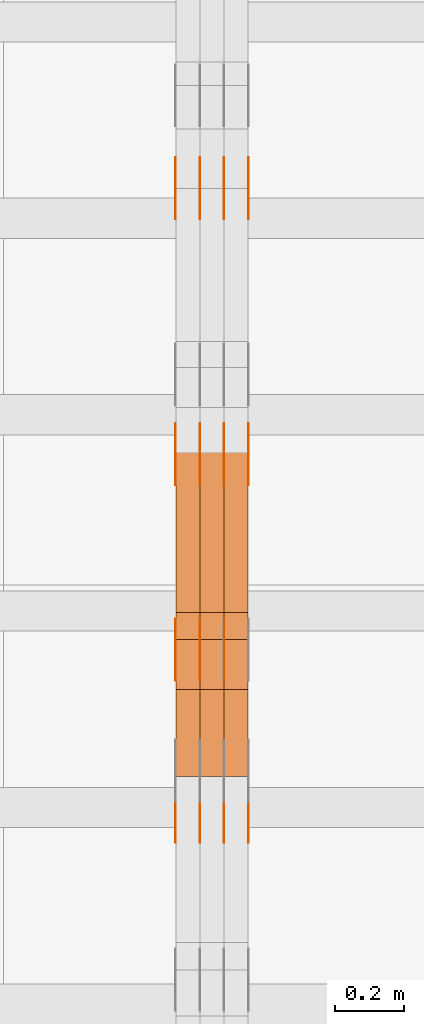
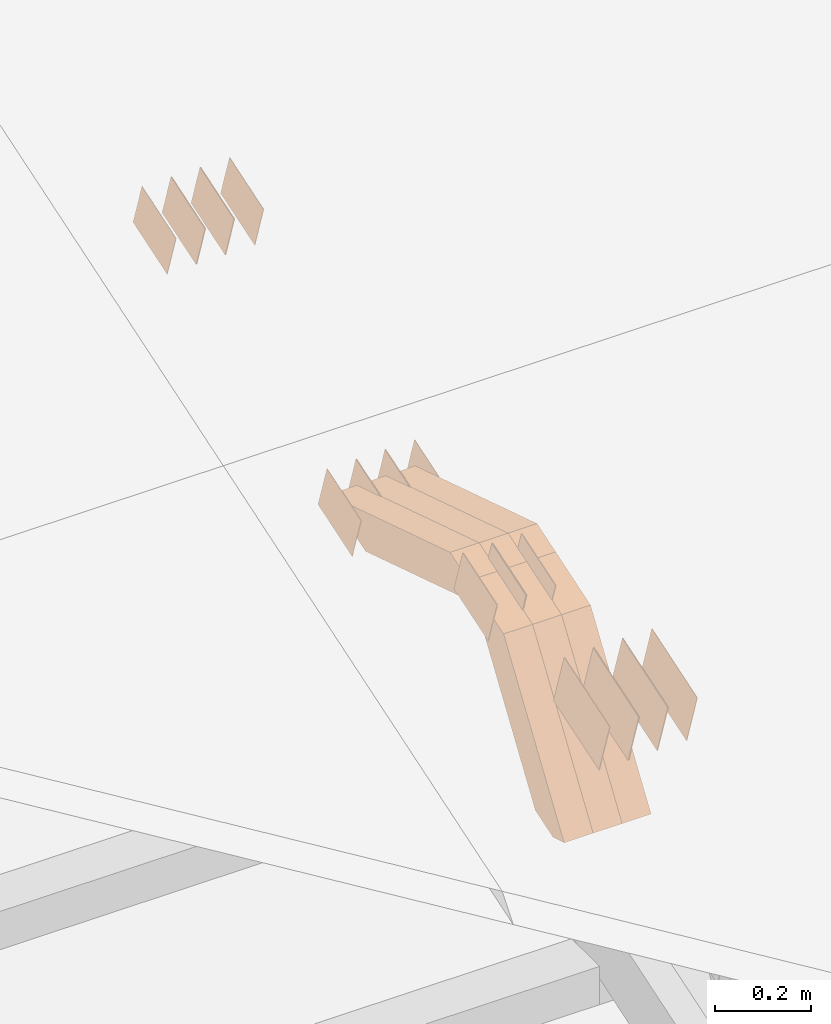
# One storey, part 130 of 385: 28 proxies.
"""IFC2X3 building model written with IfcOpenShell, lengths in millimetres."""

from ifc_helpers import new_model, entity, si_unit, converted_unit, derived_unit, direction, frame, origin, place, context, subcontext, project, spatial, polyline, outline, extrude, source, transform, mapped, material, type_object, type_shapes, element, save


model = new_model("IFC2X3")

# Units and contexts
model_context = context("Model", 3, precision=0.01, world=origin(), true_north=direction((6.12303176911189e-17, 1.0)))
body_context = subcontext(model_context, "Body", "Model", "MODEL_VIEW")
ifc_project = project(units=[si_unit("LENGTHUNIT", "METRE", prefix="MILLI"), si_unit("AREAUNIT", "SQUARE_METRE"), si_unit("VOLUMEUNIT", "CUBIC_METRE"), converted_unit("PLANEANGLEUNIT", "DEGREE", entity("IfcRatioMeasure", 0.0174532925199433), si_unit("PLANEANGLEUNIT", "RADIAN"), dimensions=[0, 0, 0, 0, 0, 0, 0]), si_unit("MASSUNIT", "GRAM", prefix="KILO"), derived_unit("MASSDENSITYUNIT", [(si_unit("MASSUNIT", "GRAM", prefix="KILO"), 1), (si_unit("LENGTHUNIT", "METRE"), -3)]), si_unit("TIMEUNIT", "SECOND"), si_unit("FREQUENCYUNIT", "HERTZ"), si_unit("THERMODYNAMICTEMPERATUREUNIT", "DEGREE_CELSIUS"), derived_unit("THERMALTRANSMITTANCEUNIT", [(si_unit("MASSUNIT", "GRAM", prefix="KILO"), 1), (si_unit("THERMODYNAMICTEMPERATUREUNIT", "KELVIN"), -1), (si_unit("TIMEUNIT", "SECOND"), -3)]), derived_unit("VOLUMETRICFLOWRATEUNIT", [(si_unit("LENGTHUNIT", "METRE"), 3), (si_unit("TIMEUNIT", "SECOND"), -1)]), si_unit("ELECTRICCURRENTUNIT", "AMPERE"), si_unit("ELECTRICVOLTAGEUNIT", "VOLT"), si_unit("POWERUNIT", "WATT"), si_unit("FORCEUNIT", "NEWTON", prefix="KILO"), si_unit("ILLUMINANCEUNIT", "LUX"), si_unit("LUMINOUSFLUXUNIT", "LUMEN"), si_unit("LUMINOUSINTENSITYUNIT", "CANDELA"), derived_unit("USERDEFINED", [(si_unit("MASSUNIT", "GRAM", prefix="KILO"), -1), (si_unit("LENGTHUNIT", "METRE"), -2), (si_unit("TIMEUNIT", "SECOND"), 3), (si_unit("LUMINOUSFLUXUNIT", "LUMEN"), 1)]), derived_unit("LINEARVELOCITYUNIT", [(si_unit("LENGTHUNIT", "METRE"), 1), (si_unit("TIMEUNIT", "SECOND"), -1)]), si_unit("PRESSUREUNIT", "PASCAL"), derived_unit("USERDEFINED", [(si_unit("LENGTHUNIT", "METRE"), -2), (si_unit("MASSUNIT", "GRAM", prefix="KILO"), 1), (si_unit("TIMEUNIT", "SECOND"), -2)])], contexts=[model_context])

# Site, building, storey
site_placement = place(None, origin())
site = spatial("IfcSite", under=ifc_project, at=site_placement, CompositionType="ELEMENT")
building_placement = place(site_placement, origin())
building = spatial("IfcBuilding", under=site, at=building_placement, CompositionType="ELEMENT")
storey_placement = place(building_placement, origin())
storey = spatial("IfcBuildingStorey", under=building, at=storey_placement, Name="Default", CompositionType="ELEMENT", Elevation=0.0)

# Proxies
ifc_material_1 = material(Name="IfcSurfaceStyle #379590")
building_element_proxy_type_1 = type_object("IfcBuildingElementProxyType", PredefinedType="NOTDEFINED", material=ifc_material_1)
shared_shape_1 = source(origin(), body_context, "Body", "SweptSolid", [
    extrude(outline(polyline([(-74.9998754286198, -60.0000016373433), (74.9998605591145, -60.0000016373433), (74.999875428618, 60.0000016373433), (-74.9998605591127, 60.0000016373433), (-74.9998754286198, -60.0000016373433)])), frame((75.0007059026038, 60.000210935219, 0.0), z_axis=(0.0, 0.0, 1.0), x_axis=(-1.0, 0.0, 0.0)), (0.0, 0.0, 1.0), 1.3),
])
type_shapes(building_element_proxy_type_1, [shared_shape_1])
proxy_1_placement = place(building_placement, frame((30386.3, 6760.15341914203, 1372.60670336718), z_axis=(-1.0, 0.0, 0.0), x_axis=(0.0, 0.951056516295124, 0.309016994375039)))
element("IfcBuildingElementProxy", 1, at=proxy_1_placement, inside=storey, type_object=building_element_proxy_type_1, material=ifc_material_1, context=body_context, shape_type="MappedRepresentation", body=[
    mapped(shared_shape_1, transform((0.0, 0.0, 0.0), scale=1.0)),
])
ifc_material_2 = material(Name="IfcSurfaceStyle #379533")
building_element_proxy_type_2 = type_object("IfcBuildingElementProxyType", PredefinedType="NOTDEFINED", material=ifc_material_2)
shared_shape_2 = source(origin(), body_context, "Body", "SweptSolid", [
    extrude(outline(polyline([(-74.9998754286198, -60.0000016373433), (74.9998605591145, -60.0000016373433), (74.999875428618, 60.0000016373433), (-74.9998605591127, 60.0000016373433), (-74.9998754286198, -60.0000016373433)])), frame((75.0007059026038, 60.000210935219, 0.0), z_axis=(0.0, 0.0, 1.0), x_axis=(-1.0, 0.0, 0.0)), (0.0, 0.0, 1.0), 1.3),
])
type_shapes(building_element_proxy_type_2, [shared_shape_2])
proxy_2_placement = place(building_placement, frame((30315.0, 6760.15341914203, 1372.60670336718), z_axis=(-1.0, 0.0, 0.0), x_axis=(0.0, 0.951056516295124, 0.309016994375039)))
element("IfcBuildingElementProxy", 2, at=proxy_2_placement, inside=storey, type_object=building_element_proxy_type_2, material=ifc_material_2, context=body_context, shape_type="MappedRepresentation", body=[
    mapped(shared_shape_2, transform((0.0, 0.0, 0.0), scale=1.0)),
])
ifc_material_3 = material(Name="IfcSurfaceStyle #379476")
building_element_proxy_type_3 = type_object("IfcBuildingElementProxyType", PredefinedType="NOTDEFINED", material=ifc_material_3)
shared_shape_3 = source(origin(), body_context, "Body", "SweptSolid", [
    extrude(outline(polyline([(-74.9998754286198, -60.0000016373433), (74.9998605591145, -60.0000016373433), (74.999875428618, 60.0000016373433), (-74.9998605591127, 60.0000016373433), (-74.9998754286198, -60.0000016373433)])), frame((75.0007059026038, 60.000210935219, 0.0), z_axis=(0.0, 0.0, 1.0), x_axis=(-1.0, 0.0, 0.0)), (0.0, 0.0, 1.0), 1.3),
])
type_shapes(building_element_proxy_type_3, [shared_shape_3])
proxy_3_placement = place(building_placement, frame((30316.3, 6760.15341914203, 1372.60670336718), z_axis=(-1.0, 0.0, 0.0), x_axis=(0.0, 0.951056516295124, 0.309016994375039)))
element("IfcBuildingElementProxy", 3, at=proxy_3_placement, inside=storey, type_object=building_element_proxy_type_3, material=ifc_material_3, context=body_context, shape_type="MappedRepresentation", body=[
    mapped(shared_shape_3, transform((0.0, 0.0, 0.0), scale=1.0)),
])
ifc_material_4 = material(Name="IfcSurfaceStyle #379419")
building_element_proxy_type_4 = type_object("IfcBuildingElementProxyType", PredefinedType="NOTDEFINED", material=ifc_material_4)
shared_shape_4 = source(origin(), body_context, "Body", "SweptSolid", [
    extrude(outline(polyline([(-74.9998754286198, -60.0000016373433), (74.9998605591145, -60.0000016373433), (74.999875428618, 60.0000016373433), (-74.9998605591127, 60.0000016373433), (-74.9998754286198, -60.0000016373433)])), frame((75.0007059026038, 60.000210935219, 0.0), z_axis=(0.0, 0.0, 1.0), x_axis=(-1.0, 0.0, 0.0)), (0.0, 0.0, 1.0), 1.29999999999999),
])
type_shapes(building_element_proxy_type_4, [shared_shape_4])
proxy_4_placement = place(building_placement, frame((30245.0, 6760.15341914203, 1372.60670336718), z_axis=(-1.0, 0.0, 0.0), x_axis=(0.0, 0.951056516295124, 0.309016994375039)))
element("IfcBuildingElementProxy", 4, at=proxy_4_placement, inside=storey, type_object=building_element_proxy_type_4, material=ifc_material_4, context=body_context, shape_type="MappedRepresentation", body=[
    mapped(shared_shape_4, transform((0.0, 0.0, 0.0), scale=1.0)),
])
ifc_material_5 = material(Name="IfcSurfaceStyle #379362")
building_element_proxy_type_5 = type_object("IfcBuildingElementProxyType", PredefinedType="NOTDEFINED", material=ifc_material_5)
shared_shape_5 = source(origin(), body_context, "Body", "SweptSolid", [
    extrude(outline(polyline([(-74.9998754286198, -60.0000016373433), (74.9998605591145, -60.0000016373433), (74.999875428618, 60.0000016373433), (-74.9998605591127, 60.0000016373433), (-74.9998754286198, -60.0000016373433)])), frame((75.0007059026038, 60.000210935219, 0.0), z_axis=(0.0, 0.0, 1.0), x_axis=(-1.0, 0.0, 0.0)), (0.0, 0.0, 1.0), 1.29999999999999),
])
type_shapes(building_element_proxy_type_5, [shared_shape_5])
proxy_5_placement = place(building_placement, frame((30246.3, 6760.15341914203, 1372.60670336718), z_axis=(-1.0, 0.0, 0.0), x_axis=(0.0, 0.951056516295124, 0.309016994375039)))
element("IfcBuildingElementProxy", 5, at=proxy_5_placement, inside=storey, type_object=building_element_proxy_type_5, material=ifc_material_5, context=body_context, shape_type="MappedRepresentation", body=[
    mapped(shared_shape_5, transform((0.0, 0.0, 0.0), scale=1.0)),
])
ifc_material_6 = material(Name="IfcSurfaceStyle #379305")
building_element_proxy_type_6 = type_object("IfcBuildingElementProxyType", PredefinedType="NOTDEFINED", material=ifc_material_6)
shared_shape_6 = source(origin(), body_context, "Body", "SweptSolid", [
    extrude(outline(polyline([(-74.9998754286198, -60.0000016373433), (74.9998605591145, -60.0000016373433), (74.999875428618, 60.0000016373433), (-74.9998605591127, 60.0000016373433), (-74.9998754286198, -60.0000016373433)])), frame((75.0007059026038, 60.000210935219, 0.0), z_axis=(0.0, 0.0, 1.0), x_axis=(-1.0, 0.0, 0.0)), (0.0, 0.0, 1.0), 1.29999999999999),
])
type_shapes(building_element_proxy_type_6, [shared_shape_6])
proxy_6_placement = place(building_placement, frame((30175.0, 6760.15341914203, 1372.60670336718), z_axis=(-1.0, 0.0, 0.0), x_axis=(0.0, 0.951056516295124, 0.309016994375039)))
element("IfcBuildingElementProxy", 6, at=proxy_6_placement, inside=storey, type_object=building_element_proxy_type_6, material=ifc_material_6, context=body_context, shape_type="MappedRepresentation", body=[
    mapped(shared_shape_6, transform((0.0, 0.0, 0.0), scale=1.0)),
])
ifc_material_7 = material(Name="IfcSurfaceStyle #373434")
building_element_proxy_type_7 = type_object("IfcBuildingElementProxyType", PredefinedType="NOTDEFINED", material=ifc_material_7)
shared_shape_7 = source(origin(), body_context, "Body", "SweptSolid", [
    extrude(outline(polyline([(-74.9998801438441, -60.0000306612856), (74.9998747047876, -60.0000306612856), (74.9998707133936, 60.0000306612856), (-74.9998652743371, 60.0000306612856), (-74.9998801438441, -60.0000306612856)])), frame((75.0000206139493, 60.0000306612856, 0.0), z_axis=(0.0, 0.0, 1.0), x_axis=(-1.0, 0.0, 0.0)), (0.0, 0.0, 1.0), 1.3),
])
type_shapes(building_element_proxy_type_7, [shared_shape_7])
proxy_7_placement = place(building_placement, frame((30386.3, 5987.08381858242, 1121.42116774683), z_axis=(-1.0, 0.0, 0.0), x_axis=(0.0, 0.951056516295124, 0.309016994375039)))
element("IfcBuildingElementProxy", 7, at=proxy_7_placement, inside=storey, type_object=building_element_proxy_type_7, material=ifc_material_7, context=body_context, shape_type="MappedRepresentation", body=[
    mapped(shared_shape_7, transform((0.0, 0.0, 0.0), scale=1.0)),
])
ifc_material_8 = material(Name="IfcSurfaceStyle #373377")
building_element_proxy_type_8 = type_object("IfcBuildingElementProxyType", PredefinedType="NOTDEFINED", material=ifc_material_8)
shared_shape_8 = source(origin(), body_context, "Body", "SweptSolid", [
    extrude(outline(polyline([(-74.9998801438441, -60.0000306612856), (74.9998747047876, -60.0000306612856), (74.9998707133936, 60.0000306612856), (-74.9998652743371, 60.0000306612856), (-74.9998801438441, -60.0000306612856)])), frame((75.0000206139493, 60.0000306612856, 0.0), z_axis=(0.0, 0.0, 1.0), x_axis=(-1.0, 0.0, 0.0)), (0.0, 0.0, 1.0), 1.3),
])
type_shapes(building_element_proxy_type_8, [shared_shape_8])
proxy_8_placement = place(building_placement, frame((30315.0, 5987.08381858242, 1121.42116774683), z_axis=(-1.0, 0.0, 0.0), x_axis=(0.0, 0.951056516295124, 0.309016994375039)))
element("IfcBuildingElementProxy", 8, at=proxy_8_placement, inside=storey, type_object=building_element_proxy_type_8, material=ifc_material_8, context=body_context, shape_type="MappedRepresentation", body=[
    mapped(shared_shape_8, transform((0.0, 0.0, 0.0), scale=1.0)),
])
ifc_material_9 = material(Name="IfcSurfaceStyle #373320")
building_element_proxy_type_9 = type_object("IfcBuildingElementProxyType", PredefinedType="NOTDEFINED", material=ifc_material_9)
shared_shape_9 = source(origin(), body_context, "Body", "SweptSolid", [
    extrude(outline(polyline([(-74.9998801438441, -60.0000306612856), (74.9998747047876, -60.0000306612856), (74.9998707133936, 60.0000306612856), (-74.9998652743371, 60.0000306612856), (-74.9998801438441, -60.0000306612856)])), frame((75.0000206139493, 60.0000306612856, 0.0), z_axis=(0.0, 0.0, 1.0), x_axis=(-1.0, 0.0, 0.0)), (0.0, 0.0, 1.0), 1.3),
])
type_shapes(building_element_proxy_type_9, [shared_shape_9])
proxy_9_placement = place(building_placement, frame((30316.3, 5987.08381858242, 1121.42116774683), z_axis=(-1.0, 0.0, 0.0), x_axis=(0.0, 0.951056516295124, 0.309016994375039)))
element("IfcBuildingElementProxy", 9, at=proxy_9_placement, inside=storey, type_object=building_element_proxy_type_9, material=ifc_material_9, context=body_context, shape_type="MappedRepresentation", body=[
    mapped(shared_shape_9, transform((0.0, 0.0, 0.0), scale=1.0)),
])
ifc_material_10 = material(Name="IfcSurfaceStyle #373263")
building_element_proxy_type_10 = type_object("IfcBuildingElementProxyType", PredefinedType="NOTDEFINED", material=ifc_material_10)
shared_shape_10 = source(origin(), body_context, "Body", "SweptSolid", [
    extrude(outline(polyline([(-74.9998801438441, -60.0000306612856), (74.9998747047876, -60.0000306612856), (74.9998707133936, 60.0000306612856), (-74.9998652743371, 60.0000306612856), (-74.9998801438441, -60.0000306612856)])), frame((75.0000206139493, 60.0000306612856, 0.0), z_axis=(0.0, 0.0, 1.0), x_axis=(-1.0, 0.0, 0.0)), (0.0, 0.0, 1.0), 1.29999999999999),
])
type_shapes(building_element_proxy_type_10, [shared_shape_10])
proxy_10_placement = place(building_placement, frame((30245.0, 5987.08381858242, 1121.42116774683), z_axis=(-1.0, 0.0, 0.0), x_axis=(0.0, 0.951056516295124, 0.309016994375039)))
element("IfcBuildingElementProxy", 10, at=proxy_10_placement, inside=storey, type_object=building_element_proxy_type_10, material=ifc_material_10, context=body_context, shape_type="MappedRepresentation", body=[
    mapped(shared_shape_10, transform((0.0, 0.0, 0.0), scale=1.0)),
])
ifc_material_11 = material(Name="IfcSurfaceStyle #373206")
building_element_proxy_type_11 = type_object("IfcBuildingElementProxyType", PredefinedType="NOTDEFINED", material=ifc_material_11)
shared_shape_11 = source(origin(), body_context, "Body", "SweptSolid", [
    extrude(outline(polyline([(-74.9998801438441, -60.0000306612856), (74.9998747047876, -60.0000306612856), (74.9998707133936, 60.0000306612856), (-74.9998652743371, 60.0000306612856), (-74.9998801438441, -60.0000306612856)])), frame((75.0000206139493, 60.0000306612856, 0.0), z_axis=(0.0, 0.0, 1.0), x_axis=(-1.0, 0.0, 0.0)), (0.0, 0.0, 1.0), 1.29999999999999),
])
type_shapes(building_element_proxy_type_11, [shared_shape_11])
proxy_11_placement = place(building_placement, frame((30246.3, 5987.08381858242, 1121.42116774683), z_axis=(-1.0, 0.0, 0.0), x_axis=(0.0, 0.951056516295124, 0.309016994375039)))
element("IfcBuildingElementProxy", 11, at=proxy_11_placement, inside=storey, type_object=building_element_proxy_type_11, material=ifc_material_11, context=body_context, shape_type="MappedRepresentation", body=[
    mapped(shared_shape_11, transform((0.0, 0.0, 0.0), scale=1.0)),
])
ifc_material_12 = material(Name="IfcSurfaceStyle #373149")
building_element_proxy_type_12 = type_object("IfcBuildingElementProxyType", PredefinedType="NOTDEFINED", material=ifc_material_12)
shared_shape_12 = source(origin(), body_context, "Body", "SweptSolid", [
    extrude(outline(polyline([(-74.9998801438441, -60.0000306612856), (74.9998747047876, -60.0000306612856), (74.9998707133936, 60.0000306612856), (-74.9998652743371, 60.0000306612856), (-74.9998801438441, -60.0000306612856)])), frame((75.0000206139493, 60.0000306612856, 0.0), z_axis=(0.0, 0.0, 1.0), x_axis=(-1.0, 0.0, 0.0)), (0.0, 0.0, 1.0), 1.29999999999999),
])
type_shapes(building_element_proxy_type_12, [shared_shape_12])
proxy_12_placement = place(building_placement, frame((30175.0, 5987.08381858242, 1121.42116774683), z_axis=(-1.0, 0.0, 0.0), x_axis=(0.0, 0.951056516295124, 0.309016994375039)))
element("IfcBuildingElementProxy", 12, at=proxy_12_placement, inside=storey, type_object=building_element_proxy_type_12, material=ifc_material_12, context=body_context, shape_type="MappedRepresentation", body=[
    mapped(shared_shape_12, transform((0.0, 0.0, 0.0), scale=1.0)),
])
ifc_material_13 = material(Name="IfcSurfaceStyle #367848")
building_element_proxy_type_13 = type_object("IfcBuildingElementProxyType", PredefinedType="NOTDEFINED", material=ifc_material_13)
shared_shape_13 = source(origin(), body_context, "Body", "SweptSolid", [
    extrude(outline(polyline([(-74.9998565677224, -60.0000596852342), (74.9998794200083, -60.0000596852342), (74.9998565677242, 60.0000596852342), (-74.9998794200101, 60.0000596852342), (-74.9998565677224, -60.0000596852342)])), frame((74.9998794200083, 60.0000596852342, 0.0), z_axis=(0.0, 0.0, 1.0), x_axis=(-1.0, 0.0, 0.0)), (0.0, 0.0, 1.0), 1.3),
])
type_shapes(building_element_proxy_type_13, [shared_shape_13])
proxy_13_placement = place(building_placement, frame((30316.3, 5418.6991737875, 1250.81341892098), z_axis=(-1.0, 0.0, 0.0), x_axis=(0.0, 0.951056516295154, 0.309016994374948)))
element("IfcBuildingElementProxy", 13, at=proxy_13_placement, inside=storey, type_object=building_element_proxy_type_13, material=ifc_material_13, context=body_context, shape_type="MappedRepresentation", body=[
    mapped(shared_shape_13, transform((0.0, 0.0, 0.0), scale=1.0)),
])
ifc_material_14 = material(Name="IfcSurfaceStyle #367791")
building_element_proxy_type_14 = type_object("IfcBuildingElementProxyType", PredefinedType="NOTDEFINED", material=ifc_material_14)
shared_shape_14 = source(origin(), body_context, "Body", "SweptSolid", [
    extrude(outline(polyline([(-74.9998565677224, -60.0000596852342), (74.9998794200083, -60.0000596852342), (74.9998565677242, 60.0000596852342), (-74.9998794200101, 60.0000596852342), (-74.9998565677224, -60.0000596852342)])), frame((74.9998794200083, 60.0000596852342, 0.0), z_axis=(0.0, 0.0, 1.0), x_axis=(-1.0, 0.0, 0.0)), (0.0, 0.0, 1.0), 1.29999999999999),
])
type_shapes(building_element_proxy_type_14, [shared_shape_14])
proxy_14_placement = place(building_placement, frame((30245.0, 5418.6991737875, 1250.81341892098), z_axis=(-1.0, 0.0, 0.0), x_axis=(0.0, 0.951056516295154, 0.309016994374948)))
element("IfcBuildingElementProxy", 14, at=proxy_14_placement, inside=storey, type_object=building_element_proxy_type_14, material=ifc_material_14, context=body_context, shape_type="MappedRepresentation", body=[
    mapped(shared_shape_14, transform((0.0, 0.0, 0.0), scale=1.0)),
])
ifc_material_15 = material(Name="IfcSurfaceStyle #367734")
building_element_proxy_type_15 = type_object("IfcBuildingElementProxyType", PredefinedType="NOTDEFINED", material=ifc_material_15)
shared_shape_15 = source(origin(), body_context, "Body", "SweptSolid", [
    extrude(outline(polyline([(-74.9998565677224, -60.0000596852342), (74.9998794200083, -60.0000596852342), (74.9998565677242, 60.0000596852342), (-74.9998794200101, 60.0000596852342), (-74.9998565677224, -60.0000596852342)])), frame((74.9998794200083, 60.0000596852342, 0.0), z_axis=(0.0, 0.0, 1.0), x_axis=(-1.0, 0.0, 0.0)), (0.0, 0.0, 1.0), 1.29999999999999),
])
type_shapes(building_element_proxy_type_15, [shared_shape_15])
proxy_15_placement = place(building_placement, frame((30246.3, 5418.6991737875, 1250.81341892098), z_axis=(-1.0, 0.0, 0.0), x_axis=(0.0, 0.951056516295154, 0.309016994374948)))
element("IfcBuildingElementProxy", 15, at=proxy_15_placement, inside=storey, type_object=building_element_proxy_type_15, material=ifc_material_15, context=body_context, shape_type="MappedRepresentation", body=[
    mapped(shared_shape_15, transform((0.0, 0.0, 0.0), scale=1.0)),
])
ifc_material_16 = material(Name="IfcSurfaceStyle #367677")
building_element_proxy_type_16 = type_object("IfcBuildingElementProxyType", PredefinedType="NOTDEFINED", material=ifc_material_16)
shared_shape_16 = source(origin(), body_context, "Body", "SweptSolid", [
    extrude(outline(polyline([(-74.9998565677224, -60.0000596852342), (74.9998794200083, -60.0000596852342), (74.9998565677242, 60.0000596852342), (-74.9998794200101, 60.0000596852342), (-74.9998565677224, -60.0000596852342)])), frame((74.9998794200083, 60.0000596852342, 0.0), z_axis=(0.0, 0.0, 1.0), x_axis=(-1.0, 0.0, 0.0)), (0.0, 0.0, 1.0), 1.29999999999999),
])
type_shapes(building_element_proxy_type_16, [shared_shape_16])
proxy_16_placement = place(building_placement, frame((30175.0, 5418.6991737875, 1250.81341892098), z_axis=(-1.0, 0.0, 0.0), x_axis=(0.0, 0.951056516295154, 0.309016994374948)))
element("IfcBuildingElementProxy", 16, at=proxy_16_placement, inside=storey, type_object=building_element_proxy_type_16, material=ifc_material_16, context=body_context, shape_type="MappedRepresentation", body=[
    mapped(shared_shape_16, transform((0.0, 0.0, 0.0), scale=1.0)),
])
ifc_material_17 = material(Name="IfcSurfaceStyle #364542")
building_element_proxy_type_17 = type_object("IfcBuildingElementProxyType", PredefinedType="NOTDEFINED", material=ifc_material_17)
shared_shape_17 = source(origin(), body_context, "Body", "SweptSolid", [
    extrude(outline(polyline([(-99.9996257846169, -71.999973710258), (100.000009625089, -71.999973710258), (99.9996257846187, 71.999973710258), (-100.000009625091, 71.999973710258), (-99.9996257846169, -71.999973710258)])), frame((100.000083496635, 72.0000008245779, 0.0), z_axis=(0.0, 0.0, 1.0), x_axis=(-1.0, 0.0, 0.0)), (0.0, 0.0, 1.0), 1.3),
])
type_shapes(building_element_proxy_type_17, [shared_shape_17])
proxy_17_placement = place(building_placement, frame((30386.3, 4947.73195917316, 1225.53937157357), z_axis=(-1.0, 0.0, 0.0), x_axis=(0.0, 0.951056516295154, 0.309016994374948)))
element("IfcBuildingElementProxy", 17, at=proxy_17_placement, inside=storey, type_object=building_element_proxy_type_17, material=ifc_material_17, context=body_context, shape_type="MappedRepresentation", body=[
    mapped(shared_shape_17, transform((0.0, 0.0, 0.0), scale=1.0)),
])
ifc_material_18 = material(Name="IfcSurfaceStyle #364485")
building_element_proxy_type_18 = type_object("IfcBuildingElementProxyType", PredefinedType="NOTDEFINED", material=ifc_material_18)
shared_shape_18 = source(origin(), body_context, "Body", "SweptSolid", [
    extrude(outline(polyline([(-99.9996257846169, -71.999973710258), (100.000009625089, -71.999973710258), (99.9996257846187, 71.999973710258), (-100.000009625091, 71.999973710258), (-99.9996257846169, -71.999973710258)])), frame((100.000083496635, 72.0000008245779, 0.0), z_axis=(0.0, 0.0, 1.0), x_axis=(-1.0, 0.0, 0.0)), (0.0, 0.0, 1.0), 1.3),
])
type_shapes(building_element_proxy_type_18, [shared_shape_18])
proxy_18_placement = place(building_placement, frame((30315.0, 4947.73195917316, 1225.53937157357), z_axis=(-1.0, 0.0, 0.0), x_axis=(0.0, 0.951056516295154, 0.309016994374948)))
element("IfcBuildingElementProxy", 18, at=proxy_18_placement, inside=storey, type_object=building_element_proxy_type_18, material=ifc_material_18, context=body_context, shape_type="MappedRepresentation", body=[
    mapped(shared_shape_18, transform((0.0, 0.0, 0.0), scale=1.0)),
])
ifc_material_19 = material(Name="IfcSurfaceStyle #364428")
building_element_proxy_type_19 = type_object("IfcBuildingElementProxyType", PredefinedType="NOTDEFINED", material=ifc_material_19)
shared_shape_19 = source(origin(), body_context, "Body", "SweptSolid", [
    extrude(outline(polyline([(-99.9996257846169, -71.999973710258), (100.000009625089, -71.999973710258), (99.9996257846187, 71.999973710258), (-100.000009625091, 71.999973710258), (-99.9996257846169, -71.999973710258)])), frame((100.000083496635, 72.0000008245779, 0.0), z_axis=(0.0, 0.0, 1.0), x_axis=(-1.0, 0.0, 0.0)), (0.0, 0.0, 1.0), 1.3),
])
type_shapes(building_element_proxy_type_19, [shared_shape_19])
proxy_19_placement = place(building_placement, frame((30316.3, 4947.73195917316, 1225.53937157357), z_axis=(-1.0, 0.0, 0.0), x_axis=(0.0, 0.951056516295154, 0.309016994374948)))
element("IfcBuildingElementProxy", 19, at=proxy_19_placement, inside=storey, type_object=building_element_proxy_type_19, material=ifc_material_19, context=body_context, shape_type="MappedRepresentation", body=[
    mapped(shared_shape_19, transform((0.0, 0.0, 0.0), scale=1.0)),
])
ifc_material_20 = material(Name="IfcSurfaceStyle #364371")
building_element_proxy_type_20 = type_object("IfcBuildingElementProxyType", PredefinedType="NOTDEFINED", material=ifc_material_20)
shared_shape_20 = source(origin(), body_context, "Body", "SweptSolid", [
    extrude(outline(polyline([(-99.9996257846169, -71.999973710258), (100.000009625089, -71.999973710258), (99.9996257846187, 71.999973710258), (-100.000009625091, 71.999973710258), (-99.9996257846169, -71.999973710258)])), frame((100.000083496635, 72.0000008245779, 0.0), z_axis=(0.0, 0.0, 1.0), x_axis=(-1.0, 0.0, 0.0)), (0.0, 0.0, 1.0), 1.29999999999998),
])
type_shapes(building_element_proxy_type_20, [shared_shape_20])
proxy_20_placement = place(building_placement, frame((30245.0, 4947.73195917316, 1225.53937157357), z_axis=(-1.0, 0.0, 0.0), x_axis=(0.0, 0.951056516295154, 0.309016994374948)))
element("IfcBuildingElementProxy", 20, at=proxy_20_placement, inside=storey, type_object=building_element_proxy_type_20, material=ifc_material_20, context=body_context, shape_type="MappedRepresentation", body=[
    mapped(shared_shape_20, transform((0.0, 0.0, 0.0), scale=1.0)),
])
ifc_material_21 = material(Name="IfcSurfaceStyle #364314")
building_element_proxy_type_21 = type_object("IfcBuildingElementProxyType", PredefinedType="NOTDEFINED", material=ifc_material_21)
shared_shape_21 = source(origin(), body_context, "Body", "SweptSolid", [
    extrude(outline(polyline([(-99.9996257846169, -71.999973710258), (100.000009625089, -71.999973710258), (99.9996257846187, 71.999973710258), (-100.000009625091, 71.999973710258), (-99.9996257846169, -71.999973710258)])), frame((100.000083496635, 72.0000008245779, 0.0), z_axis=(0.0, 0.0, 1.0), x_axis=(-1.0, 0.0, 0.0)), (0.0, 0.0, 1.0), 1.29999999999998),
])
type_shapes(building_element_proxy_type_21, [shared_shape_21])
proxy_21_placement = place(building_placement, frame((30246.3, 4947.73195917316, 1225.53937157357), z_axis=(-1.0, 0.0, 0.0), x_axis=(0.0, 0.951056516295154, 0.309016994374948)))
element("IfcBuildingElementProxy", 21, at=proxy_21_placement, inside=storey, type_object=building_element_proxy_type_21, material=ifc_material_21, context=body_context, shape_type="MappedRepresentation", body=[
    mapped(shared_shape_21, transform((0.0, 0.0, 0.0), scale=1.0)),
])
ifc_material_22 = material(Name="IfcSurfaceStyle #364257")
building_element_proxy_type_22 = type_object("IfcBuildingElementProxyType", PredefinedType="NOTDEFINED", material=ifc_material_22)
shared_shape_22 = source(origin(), body_context, "Body", "SweptSolid", [
    extrude(outline(polyline([(-99.9996257846169, -71.999973710258), (100.000009625089, -71.999973710258), (99.9996257846187, 71.999973710258), (-100.000009625091, 71.999973710258), (-99.9996257846169, -71.999973710258)])), frame((100.000083496635, 72.0000008245779, 0.0), z_axis=(0.0, 0.0, 1.0), x_axis=(-1.0, 0.0, 0.0)), (0.0, 0.0, 1.0), 1.29999999999999),
])
type_shapes(building_element_proxy_type_22, [shared_shape_22])
proxy_22_placement = place(building_placement, frame((30175.0, 4947.73195917316, 1225.53937157357), z_axis=(-1.0, 0.0, 0.0), x_axis=(0.0, 0.951056516295154, 0.309016994374948)))
element("IfcBuildingElementProxy", 22, at=proxy_22_placement, inside=storey, type_object=building_element_proxy_type_22, material=ifc_material_22, context=body_context, shape_type="MappedRepresentation", body=[
    mapped(shared_shape_22, transform((0.0, 0.0, 0.0), scale=1.0)),
])
ifc_material_23 = material(Name="IfcSurfaceStyle #355200")
building_element_proxy_type_23 = type_object("IfcBuildingElementProxyType", Name="T1-W15 355198", PredefinedType="NOTDEFINED", material=ifc_material_23)
shared_shape_23 = source(origin(), body_context, "Body", "SweptSolid", [
    extrude(outline(polyline([(-243.398341390642, -47.5000170814535), (237.775741169608, -47.5000170814535), (224.054017709933, 0.000127777485579883), (157.692261395711, 47.4999531927108), (-376.12367888461, 47.4999531927107), (-243.398341390642, -47.5000170814535)])), frame((237.77637044506, 47.5003404768297, 0.0), z_axis=(0.0, 0.0, 1.0), x_axis=(-1.0, 0.0, 0.0)), (0.0, 0.0, 1.0), 70.0),
])
type_shapes(building_element_proxy_type_23, [shared_shape_23])
proxy_23_placement = place(building_placement, frame((30385.0, 5540.23242178142, 1288.84274826279), z_axis=(-1.0, 0.0, 0.0), x_axis=(0.0, 0.95322291386448, -0.302268219440466)))
element("IfcBuildingElementProxy", 23, at=proxy_23_placement, inside=storey, type_object=building_element_proxy_type_23, material=ifc_material_23, Name="T1-W15", context=body_context, shape_type="MappedRepresentation", body=[
    mapped(shared_shape_23, transform((0.0, 0.0, 0.0), scale=1.0)),
])
ifc_material_24 = material(Name="IfcSurfaceStyle #355134")
building_element_proxy_type_24 = type_object("IfcBuildingElementProxyType", Name="T1-W15 355132", PredefinedType="NOTDEFINED", material=ifc_material_24)
shared_shape_24 = source(origin(), body_context, "Body", "SweptSolid", [
    extrude(outline(polyline([(-243.398341390642, -47.5000170814535), (237.775741169608, -47.5000170814535), (224.054017709933, 0.000127777485579883), (157.692261395711, 47.4999531927108), (-376.12367888461, 47.4999531927107), (-243.398341390642, -47.5000170814535)])), frame((237.77637044506, 47.5003404768297, 0.0), z_axis=(0.0, 0.0, 1.0), x_axis=(-1.0, 0.0, 0.0)), (0.0, 0.0, 1.0), 70.0),
])
type_shapes(building_element_proxy_type_24, [shared_shape_24])
proxy_24_placement = place(building_placement, frame((30315.0, 5540.23242178142, 1288.84274826279), z_axis=(-1.0, 0.0, 0.0), x_axis=(0.0, 0.95322291386448, -0.302268219440466)))
element("IfcBuildingElementProxy", 24, at=proxy_24_placement, inside=storey, type_object=building_element_proxy_type_24, material=ifc_material_24, Name="T1-W15", context=body_context, shape_type="MappedRepresentation", body=[
    mapped(shared_shape_24, transform((0.0, 0.0, 0.0), scale=1.0)),
])
ifc_material_25 = material(Name="IfcSurfaceStyle #355068")
building_element_proxy_type_25 = type_object("IfcBuildingElementProxyType", Name="T1-W15 355066", PredefinedType="NOTDEFINED", material=ifc_material_25)
shared_shape_25 = source(origin(), body_context, "Body", "SweptSolid", [
    extrude(outline(polyline([(-243.398341390642, -47.5000170814535), (237.775741169608, -47.5000170814535), (224.054017709933, 0.000127777485579883), (157.692261395711, 47.4999531927108), (-376.12367888461, 47.4999531927107), (-243.398341390642, -47.5000170814535)])), frame((237.77637044506, 47.5003404768297, 0.0), z_axis=(0.0, 0.0, 1.0), x_axis=(-1.0, 0.0, 0.0)), (0.0, 0.0, 1.0), 70.0),
])
type_shapes(building_element_proxy_type_25, [shared_shape_25])
proxy_25_placement = place(building_placement, frame((30245.0, 5540.23242178142, 1288.84274826279), z_axis=(-1.0, 0.0, 0.0), x_axis=(0.0, 0.95322291386448, -0.302268219440466)))
element("IfcBuildingElementProxy", 25, at=proxy_25_placement, inside=storey, type_object=building_element_proxy_type_25, material=ifc_material_25, Name="T1-W15", context=body_context, shape_type="MappedRepresentation", body=[
    mapped(shared_shape_25, transform((0.0, 0.0, 0.0), scale=1.0)),
])
ifc_material_26 = material(Name="IfcSurfaceStyle #354804")
building_element_proxy_type_26 = type_object("IfcBuildingElementProxyType", Name="T1-W22 354802", PredefinedType="NOTDEFINED", material=ifc_material_26)
shared_shape_26 = source(origin(), body_context, "Body", "SweptSolid", [
    extrude(outline(polyline([(-351.940486061686, -47.5005995570677), (149.451602529695, -47.5005995570676), (209.614029773051, 0.000108554198836676), (224.491670779786, 47.5010029530092), (-231.616817020846, 47.5000876069273), (-351.940486061686, -47.5005995570677)])), frame((224.491766107217, 47.5005524294596, 0.0), z_axis=(0.0, 0.0, 1.0), x_axis=(-1.0, 2.00686044286885e-06, 0.0)), (0.0, 0.0, 1.0), 70.0),
])
type_shapes(building_element_proxy_type_26, [shared_shape_26])
proxy_26_placement = place(building_placement, frame((30385.0, 5140.03125, 812.615600585936), z_axis=(-1.0, 0.0, 0.0), x_axis=(0.0, 0.554956576676696, 0.831879316970486)))
element("IfcBuildingElementProxy", 26, at=proxy_26_placement, inside=storey, type_object=building_element_proxy_type_26, material=ifc_material_26, Name="T1-W22", context=body_context, shape_type="MappedRepresentation", body=[
    mapped(shared_shape_26, transform((0.0, 0.0, 0.0), scale=1.0)),
])
ifc_material_27 = material(Name="IfcSurfaceStyle #354738")
building_element_proxy_type_27 = type_object("IfcBuildingElementProxyType", Name="T1-W22 354736", PredefinedType="NOTDEFINED", material=ifc_material_27)
shared_shape_27 = source(origin(), body_context, "Body", "SweptSolid", [
    extrude(outline(polyline([(-351.940486061686, -47.5005995570677), (149.451602529695, -47.5005995570676), (209.614029773051, 0.000108554198836676), (224.491670779786, 47.5010029530092), (-231.616817020846, 47.5000876069273), (-351.940486061686, -47.5005995570677)])), frame((224.491766107217, 47.5005524294596, 0.0), z_axis=(0.0, 0.0, 1.0), x_axis=(-1.0, 2.00686044286885e-06, 0.0)), (0.0, 0.0, 1.0), 70.0),
])
type_shapes(building_element_proxy_type_27, [shared_shape_27])
proxy_27_placement = place(building_placement, frame((30315.0, 5140.03125, 812.615600585936), z_axis=(-1.0, 0.0, 0.0), x_axis=(0.0, 0.554956576676696, 0.831879316970486)))
element("IfcBuildingElementProxy", 27, at=proxy_27_placement, inside=storey, type_object=building_element_proxy_type_27, material=ifc_material_27, Name="T1-W22", context=body_context, shape_type="MappedRepresentation", body=[
    mapped(shared_shape_27, transform((0.0, 0.0, 0.0), scale=1.0)),
])
ifc_material_28 = material(Name="IfcSurfaceStyle #354672")
building_element_proxy_type_28 = type_object("IfcBuildingElementProxyType", Name="T1-W22 354670", PredefinedType="NOTDEFINED", material=ifc_material_28)
shared_shape_28 = source(origin(), body_context, "Body", "SweptSolid", [
    extrude(outline(polyline([(-351.940486061686, -47.5005995570677), (149.451602529695, -47.5005995570676), (209.614029773051, 0.000108554198836676), (224.491670779786, 47.5010029530092), (-231.616817020846, 47.5000876069273), (-351.940486061686, -47.5005995570677)])), frame((224.491766107217, 47.5005524294596, 0.0), z_axis=(0.0, 0.0, 1.0), x_axis=(-1.0, 2.00686044286885e-06, 0.0)), (0.0, 0.0, 1.0), 70.0),
])
type_shapes(building_element_proxy_type_28, [shared_shape_28])
proxy_28_placement = place(building_placement, frame((30245.0, 5140.03125, 812.615600585936), z_axis=(-1.0, 0.0, 0.0), x_axis=(0.0, 0.554956576676696, 0.831879316970486)))
element("IfcBuildingElementProxy", 28, at=proxy_28_placement, inside=storey, type_object=building_element_proxy_type_28, material=ifc_material_28, Name="T1-W22", context=body_context, shape_type="MappedRepresentation", body=[
    mapped(shared_shape_28, transform((0.0, 0.0, 0.0), scale=1.0)),
])

save(model, "model.ifc")
